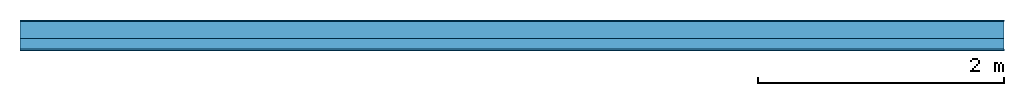
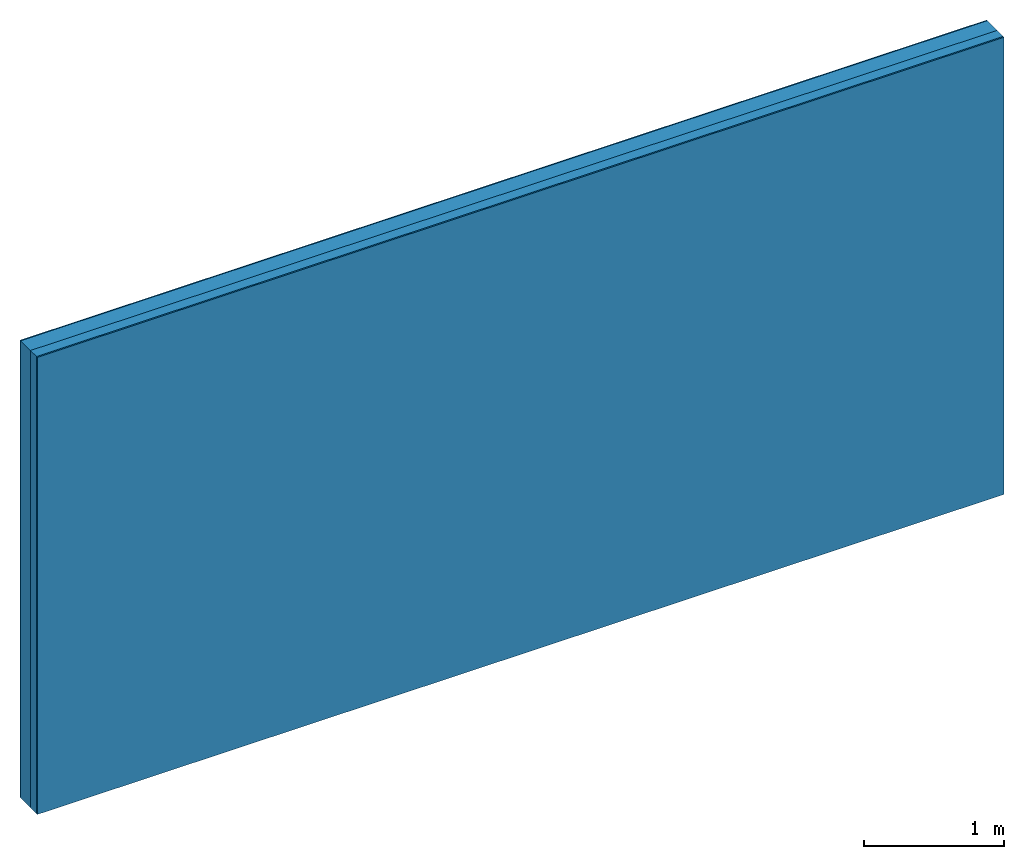
# One storey: 3 plates, 1 member, 1 element without a shape of its own.
"""IFC4 building model written with IfcOpenShell, lengths in metres."""

from ifc_helpers import new_model, si_unit, derived_unit, direction, frame, frame_2d, origin, origin_with_axes, place, context, project, spatial, rectangle, extrude, material, layer, layer_set, type_object, element, aggregate, save


model = new_model("IFC4")

# Units and contexts
plan_context = context("Plan", 3, precision=1e-05, world=origin(), true_north=direction((0.0, 1.0)))
model_context = context("Model", 3, precision=1e-05, world=origin(), true_north=direction((0.0, 1.0)))
ifc_project = project(units=[si_unit("LENGTHUNIT", "METRE"), derived_unit("SOUNDPRESSUREUNIT", [(si_unit("PRESSUREUNIT", "PASCAL", prefix="MICRO"), 0)]), si_unit("ENERGYUNIT", "JOULE", prefix="MEGA"), si_unit("MASSUNIT", "GRAM", prefix="KILO"), derived_unit("THERMALTRANSMITTANCEUNIT", [(si_unit("POWERUNIT", "WATT"), 1), (si_unit("AREAUNIT", "SQUARE_METRE"), -1), (si_unit("THERMODYNAMICTEMPERATUREUNIT", "KELVIN"), -1)]), derived_unit("AREADENSITYUNIT", [(si_unit("MASSUNIT", "GRAM", prefix="KILO"), 1), (si_unit("AREAUNIT", "SQUARE_METRE"), -1)]), derived_unit("USERDEFINED", [(si_unit("ENERGYUNIT", "JOULE", prefix="MEGA"), 1), (si_unit("AREAUNIT", "SQUARE_METRE"), -1)])], contexts=[plan_context, model_context])

# Site, building, storey
site = spatial("IfcSite", under=ifc_project)
building_placement = place(None, origin())
building = spatial("IfcBuilding", under=site, at=building_placement)
storey_placement = place(building_placement, origin())
storey = spatial("IfcBuildingStorey", under=building, at=storey_placement)

# Wall, member, plates
ifc_material_1 = material(Category="04.011")
ifc_layer_1 = layer(ifc_material_1, 0.01, Name="Surface 1")
ifc_material_2 = material(Name="Mineral wool", Category="10.008")
ifc_layer_2 = layer(ifc_material_2, 0.14, Name="outside 1st layer")
ifc_material_3 = material(Name="of the art")
ifc_layer_3 = layer(ifc_material_3, 0.0, Name="Bond")
ifc_layer_4 = layer(None, 0.087, Name="Support")
ifc_layer_5 = layer(ifc_material_3, 0.0, Name="Bond")
ifc_material_4 = material(Name="Plasterboard type A", Category="03.008")
ifc_layer_6 = layer(ifc_material_4, 0.0125, Name="1st layer")
ifc_material_5 = material(Name="joints", Category="04.017")
ifc_layer_7 = layer(ifc_material_5, 0.0, Name="Surface")
ifc_layer_set = layer_set([ifc_layer_1, ifc_layer_2, ifc_layer_3, ifc_layer_4, ifc_layer_5, ifc_layer_6, ifc_layer_7])
wall_type = type_object("IfcWallType", Name="D1019", PredefinedType="NOTDEFINED", material=ifc_layer_set)
wall_placement = place(None, frame((0.0, 0.0, 0.0), z_axis=(0.0, -1.0, 0.0), x_axis=(1.0, 0.0, 0.0)))
wall = element("IfcWall", 1, at=wall_placement, inside=storey, type_object=wall_type, material=ifc_layer_set, Name="Wall #1")
ifc_material_6 = material(Name="Solid timber panel")
member_placement = place(wall_placement, origin())
member = element("IfcMember", 2, at=member_placement, material=ifc_material_6, Name="Support", context=plan_context, shape_type="SweptSolid", body=[
    extrude(rectangle(XDim=1.0, YDim=0.087, at=frame_2d((0.5, 0.0435), x_axis=(1.0, 0.0))), frame((0.0, 4.0, 0.15), z_axis=(0.0, -1.0, 0.0), x_axis=(1.0, 0.0, 0.0)), (0.0, 0.0, 1.0), 4.0),
    extrude(rectangle(XDim=1.0, YDim=0.087, at=frame_2d((0.5, 0.0435), x_axis=(1.0, 0.0))), frame((1.0, 4.0, 0.15), z_axis=(0.0, -1.0, 0.0), x_axis=(1.0, 0.0, 0.0)), (0.0, 0.0, 1.0), 4.0),
    extrude(rectangle(XDim=1.0, YDim=0.087, at=frame_2d((0.5, 0.0435), x_axis=(1.0, 0.0))), frame((2.0, 4.0, 0.15), z_axis=(0.0, -1.0, 0.0), x_axis=(1.0, 0.0, 0.0)), (0.0, 0.0, 1.0), 4.0),
    extrude(rectangle(XDim=1.0, YDim=0.087, at=frame_2d((0.5, 0.0435), x_axis=(1.0, 0.0))), frame((3.0, 4.0, 0.15), z_axis=(0.0, -1.0, 0.0), x_axis=(1.0, 0.0, 0.0)), (0.0, 0.0, 1.0), 4.0),
    extrude(rectangle(XDim=1.0, YDim=0.087, at=frame_2d((0.5, 0.0435), x_axis=(1.0, 0.0))), frame((4.0, 4.0, 0.15), z_axis=(0.0, -1.0, 0.0), x_axis=(1.0, 0.0, 0.0)), (0.0, 0.0, 1.0), 4.0),
    extrude(rectangle(XDim=1.0, YDim=0.087, at=frame_2d((0.5, 0.0435), x_axis=(1.0, 0.0))), frame((5.0, 4.0, 0.15), z_axis=(0.0, -1.0, 0.0), x_axis=(1.0, 0.0, 0.0)), (0.0, 0.0, 1.0), 4.0),
    extrude(rectangle(XDim=1.0, YDim=0.087, at=frame_2d((0.5, 0.0435), x_axis=(1.0, 0.0))), frame((6.0, 4.0, 0.15), z_axis=(0.0, -1.0, 0.0), x_axis=(1.0, 0.0, 0.0)), (0.0, 0.0, 1.0), 4.0),
    extrude(rectangle(XDim=1.0, YDim=0.087, at=frame_2d((0.5, 0.0435), x_axis=(1.0, 0.0))), frame((7.0, 4.0, 0.15), z_axis=(0.0, -1.0, 0.0), x_axis=(1.0, 0.0, 0.0)), (0.0, 0.0, 1.0), 4.0),
])
plate_1_placement = place(wall_placement, origin())
plate_1 = element("IfcPlate", 3, at=plate_1_placement, material=ifc_material_1, Name="Surface 1", context=plan_context, shape_type="SweptSolid", body=[
    extrude(rectangle(XDim=8.0, YDim=4.0, at=frame_2d((4.0, 2.0), x_axis=(1.0, 0.0))), origin_with_axes(), (0.0, 0.0, 1.0), 0.01),
])
plate_2_placement = place(wall_placement, origin())
plate_2 = element("IfcPlate", 4, at=plate_2_placement, material=ifc_material_2, Name="outside 1st layer", context=plan_context, shape_type="SweptSolid", body=[
    extrude(rectangle(XDim=8.0, YDim=4.0, at=frame_2d((4.0, 2.0), x_axis=(1.0, 0.0))), frame((0.0, 0.0, 0.01), z_axis=(0.0, 0.0, 1.0), x_axis=(1.0, 0.0, 0.0)), (0.0, 0.0, 1.0), 0.14),
])
plate_3_placement = place(wall_placement, origin())
plate_3 = element("IfcPlate", 5, at=plate_3_placement, material=ifc_material_4, Name="1st layer", context=plan_context, shape_type="SweptSolid", body=[
    extrude(rectangle(XDim=8.0, YDim=4.0, at=frame_2d((4.0, 2.0), x_axis=(1.0, 0.0))), frame((0.0, 0.0, 0.237), z_axis=(0.0, 0.0, 1.0), x_axis=(1.0, 0.0, 0.0)), (0.0, 0.0, 1.0), 0.0125),
])
aggregate(wall, [plate_1, plate_2, member, plate_3])

save(model, "model.ifc")
